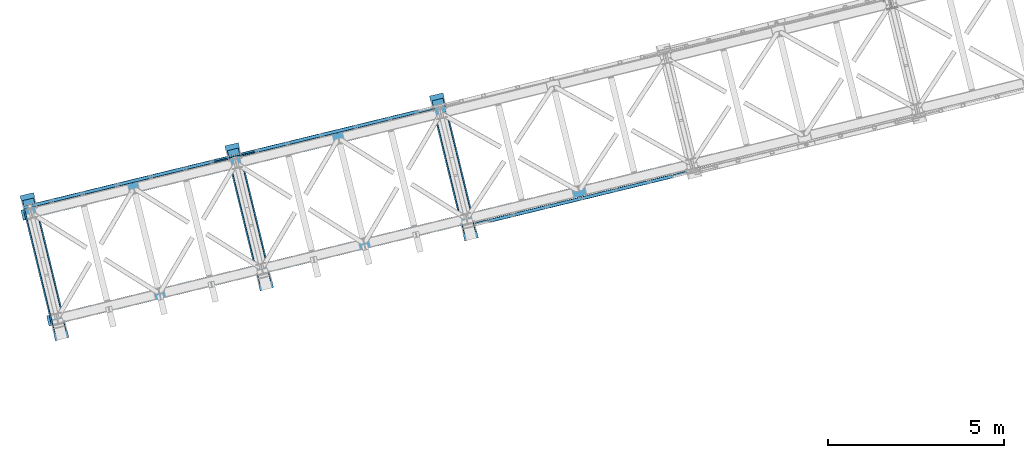
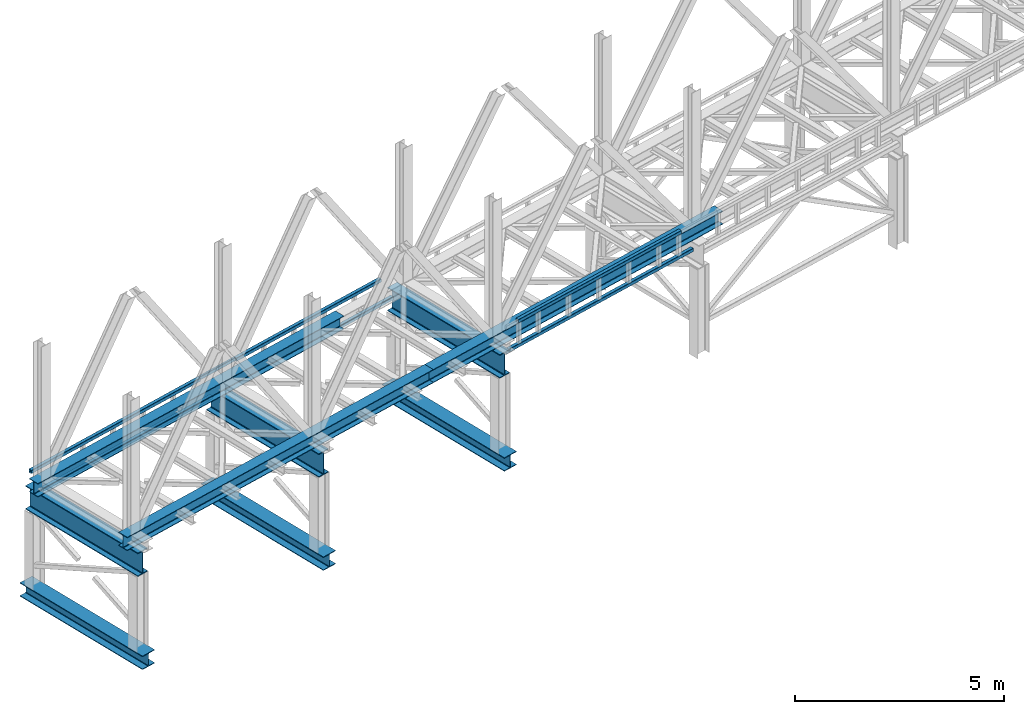
# One storey, part 15 of 92: 16 beams.
"""IFC4 building model written with IfcOpenShell, lengths in millimetres."""

from ifc_helpers import new_model, entity, si_unit, converted_unit, derived_unit, direction, frame, origin, place, context, subcontext, project, spatial, indexed_curve, outline, extrude, material, type_object, element, save


model = new_model("IFC4")

# Units and contexts
model_context = context("Model", 3, precision=0.01, world=origin(), true_north=direction((6.12303176911189e-17, 1.0)))
plan_context = context("Plan", 3, precision=0.01, world=origin(), true_north=direction((6.12303176911189e-17, 1.0)))
body_context = subcontext(model_context, "Body", "Model", "MODEL_VIEW")
ifc_project = project(units=[si_unit("LENGTHUNIT", "METRE", prefix="MILLI"), si_unit("AREAUNIT", "SQUARE_METRE"), si_unit("VOLUMEUNIT", "CUBIC_METRE"), converted_unit("PLANEANGLEUNIT", "DEGREE", entity("IfcRatioMeasure", 0.0174532925199433), si_unit("PLANEANGLEUNIT", "RADIAN"), dimensions=[0, 0, 0, 0, 0, 0, 0]), si_unit("MASSUNIT", "GRAM", prefix="KILO"), derived_unit("MASSDENSITYUNIT", [(si_unit("MASSUNIT", "GRAM", prefix="KILO"), 1), (si_unit("LENGTHUNIT", "METRE"), -3)]), derived_unit("MOMENTOFINERTIAUNIT", [(si_unit("LENGTHUNIT", "METRE"), 4)]), si_unit("TIMEUNIT", "SECOND"), si_unit("FREQUENCYUNIT", "HERTZ"), si_unit("THERMODYNAMICTEMPERATUREUNIT", "DEGREE_CELSIUS"), derived_unit("THERMALTRANSMITTANCEUNIT", [(si_unit("MASSUNIT", "GRAM", prefix="KILO"), 1), (si_unit("THERMODYNAMICTEMPERATUREUNIT", "KELVIN"), -1), (si_unit("TIMEUNIT", "SECOND"), -3)]), derived_unit("VOLUMETRICFLOWRATEUNIT", [(si_unit("LENGTHUNIT", "METRE"), 3), (si_unit("TIMEUNIT", "SECOND"), -1)]), derived_unit("MASSFLOWRATEUNIT", [(si_unit("MASSUNIT", "GRAM", prefix="KILO"), 1), (si_unit("TIMEUNIT", "SECOND"), -1)]), derived_unit("ROTATIONALFREQUENCYUNIT", [(si_unit("TIMEUNIT", "SECOND"), -1)]), si_unit("ELECTRICCURRENTUNIT", "AMPERE"), si_unit("ELECTRICVOLTAGEUNIT", "VOLT"), si_unit("POWERUNIT", "WATT"), si_unit("FORCEUNIT", "NEWTON", prefix="KILO"), si_unit("ILLUMINANCEUNIT", "LUX"), si_unit("LUMINOUSFLUXUNIT", "LUMEN"), si_unit("LUMINOUSINTENSITYUNIT", "CANDELA"), derived_unit("USERDEFINED", [(si_unit("MASSUNIT", "GRAM", prefix="KILO"), -1), (si_unit("LENGTHUNIT", "METRE"), -2), (si_unit("TIMEUNIT", "SECOND"), 3), (si_unit("LUMINOUSFLUXUNIT", "LUMEN"), 1)]), derived_unit("LINEARVELOCITYUNIT", [(si_unit("LENGTHUNIT", "METRE"), 1), (si_unit("TIMEUNIT", "SECOND"), -1)]), si_unit("PRESSUREUNIT", "PASCAL"), derived_unit("USERDEFINED", [(si_unit("LENGTHUNIT", "METRE"), -2), (si_unit("MASSUNIT", "GRAM", prefix="KILO"), 1), (si_unit("TIMEUNIT", "SECOND"), -2)]), derived_unit("LINEARFORCEUNIT", [(si_unit("MASSUNIT", "GRAM", prefix="KILO"), 1), (si_unit("LENGTHUNIT", "METRE"), 1), (si_unit("TIMEUNIT", "SECOND"), -2), (si_unit("LENGTHUNIT", "METRE"), -1)]), derived_unit("PLANARFORCEUNIT", [(si_unit("MASSUNIT", "GRAM", prefix="KILO"), 1), (si_unit("LENGTHUNIT", "METRE"), 1), (si_unit("TIMEUNIT", "SECOND"), -2), (si_unit("LENGTHUNIT", "METRE"), -2)])], contexts=[model_context, plan_context])

# Site, building, storey
site_placement = place(None, origin())
site = spatial("IfcSite", under=ifc_project, at=site_placement, CompositionType="ELEMENT")
building_placement = place(site_placement, origin())
building = spatial("IfcBuilding", under=site, at=building_placement, CompositionType="ELEMENT")
storey_placement = place(building_placement, frame((0.0, 0.0, 15900.0)))
storey = spatial("IfcBuildingStorey", under=building, at=storey_placement, Name="05", CompositionType="ELEMENT", Elevation=15900.0)

# Beams
ifc_material = material(Name="Metal painted (White)")
beam_type = type_object("IfcBeamType", PredefinedType="BEAM")
placement = place(storey_placement, origin())
element("IfcBeam", 1, at=placement, inside=storey, type_object=beam_type, material=ifc_material, ObjectType="Steel Beam", PredefinedType="BEAM", context=body_context, shape_type="SweptSolid", body=[
    extrude(outline(indexed_curve([(-199.999999999998, -200.000000000009), (-180.0, -200.000000000009), (-180.0, -28.500000000011), (-178.325349715245, -20.0809644879738), (-173.556349186101, -12.9436508139005), (-166.419035512029, -8.17465028475953), (-157.999999999999, -6.50000000000747), (158.000000000001, -6.50000000000747), (166.419035512033, -8.17465028475953), (173.556349186107, -12.9436508139005), (178.325349715251, -20.0809644879738), (180.000000000002, -28.500000000011), (180.000000000002, -200.000000000009), (200.0, -200.000000000009), (200.0, 199.999999999991), (180.000000000002, 199.999999999991), (180.000000000002, 28.4999999999932), (178.325349715247, 20.0809644879561), (173.556349186107, 12.9436508138827), (166.419035512033, 8.1746502847418), (158.000000000001, 6.49999999998974), (-157.999999999999, 6.49999999999861), (-166.419035512029, 8.17465028475066), (-173.556349186101, 12.9436508139005), (-178.325349715245, 20.080964487965), (-179.999999999998, 28.5000000000021), (-180.0, 199.999999999991), (-199.999999999998, 199.999999999991), (-199.999999999998, -200.000000000009)], self_intersect=False)), frame((-60133.55, 2325.82, 198.0), z_axis=(-0.236826092990339, 0.971552058141473, 0.0), x_axis=(0.0, 0.0, 1.0)), (0.0, 0.0, 1.0), 4250.00000000001),
])
element("IfcBeam", 2, at=placement, inside=storey, type_object=beam_type, material=ifc_material, ObjectType="Steel Beam", PredefinedType="BEAM", context=body_context, shape_type="SweptSolid", body=[
    extrude(outline(indexed_curve([(-345.500000000002, -160.000000000002), (-322.5, -160.000000000002), (-322.5, -37.4999999999994), (-320.216385975338, -26.0194970290429), (-313.713203435595, -16.2867965644056), (-303.980502970953, -9.78361402465815), (-292.499999999998, -7.49999999999633), (292.500000000001, -7.49999999999633), (303.980502970953, -9.78361402465815), (313.713203435597, -16.2867965644056), (320.21638597534, -26.0194970290429), (322.5, -37.4999999999994), (322.5, -160.000000000002), (345.499999999997, -160.000000000002), (345.499999999997, 160.000000000002), (322.5, 160.000000000002), (322.5, 37.4999999999994), (320.21638597534, 26.0194970290429), (313.713203435597, 16.2867965644056), (303.980502970953, 9.78361402465815), (292.500000000001, 7.49999999999633), (-292.499999999998, 7.50000000000526), (-303.980502970953, 9.78361402466708), (-313.713203435595, 16.2867965644056), (-320.216385975338, 26.0194970290429), (-322.5, 37.4999999999994), (-322.5, 160.000000000002), (-345.500000000002, 160.000000000002), (-345.500000000002, -160.000000000002)], self_intersect=False)), frame((-60180.91, 2520.13, 2947.5), z_axis=(-0.236826092990334, 0.971552058141474, 0.0), x_axis=(0.0, 0.0, 1.0)), (0.0, 0.0, 1.0), 3899.99999999999),
])
element("IfcBeam", 3, at=placement, inside=storey, type_object=beam_type, material=ifc_material, ObjectType="Steel Beam", PredefinedType="BEAM", context=body_context, shape_type="SweptSolid", body=[
    extrude(outline(indexed_curve([(-199.999999999998, -200.0), (-180.0, -200.0), (-180.0, -28.5000000000021), (-178.325349715245, -20.080964487965), (-173.556349186101, -12.9436508138917), (-166.419035512029, -8.17465028475066), (-157.999999999999, -6.49999999999867), (158.000000000001, -6.49999999999867), (166.419035512033, -8.17465028475066), (173.556349186107, -12.9436508138917), (178.325349715251, -20.080964487965), (180.000000000002, -28.5000000000021), (180.000000000002, -200.0), (200.0, -200.0), (200.0, 200.0), (180.000000000002, 200.0), (180.000000000002, 28.5000000000021), (178.325349715247, 20.080964487965), (173.556349186107, 12.9436508138917), (166.419035512033, 8.17465028475066), (158.000000000001, 6.49999999999854), (-157.999999999999, 6.50000000000747), (-166.419035512029, 8.17465028475959), (-173.556349186101, 12.9436508139094), (-178.325349715245, 20.0809644879738), (-179.999999999998, 28.500000000011), (-180.0, 200.0), (-199.999999999998, 200.0), (-199.999999999998, -200.0)], self_intersect=False)), frame((-54304.24, 3746.78, 198.0), z_axis=(-0.236826092990342, 0.971552058141472, 0.0), x_axis=(0.0, 0.0, 1.0)), (0.0, 0.0, 1.0), 4250.0),
])
element("IfcBeam", 4, at=placement, inside=storey, type_object=beam_type, material=ifc_material, ObjectType="Steel Beam", PredefinedType="BEAM", context=body_context, shape_type="SweptSolid", body=[
    extrude(outline(indexed_curve([(-345.500000000002, -159.999999999993), (-322.5, -159.999999999993), (-322.5, -37.4999999999906), (-320.216385975338, -26.0194970290341), (-313.713203435595, -16.2867965643968), (-303.980502970953, -9.78361402464935), (-292.499999999998, -7.4999999999874), (292.500000000001, -7.4999999999874), (303.980502970953, -9.78361402464935), (313.713203435597, -16.2867965643968), (320.21638597534, -26.0194970290341), (322.5, -37.4999999999906), (322.5, -159.999999999993), (345.499999999997, -159.999999999993), (345.499999999997, 160.000000000011), (322.5, 160.000000000011), (322.5, 37.5000000000083), (320.21638597534, 26.0194970290519), (313.713203435597, 16.2867965644145), (303.980502970953, 9.78361402466708), (292.500000000001, 7.50000000000526), (-292.499999999998, 7.50000000001406), (-303.980502970953, 9.78361402466708), (-313.713203435595, 16.2867965644145), (-320.216385975338, 26.0194970290519), (-322.5, 37.5000000000083), (-322.5, 160.000000000011), (-345.500000000002, 160.000000000011), (-345.500000000002, -159.999999999993)], self_intersect=False)), frame((-54351.6, 3941.09, 2947.5), z_axis=(-0.236826092990334, 0.971552058141474, 0.0), x_axis=(0.0, 0.0, 1.0)), (0.0, 0.0, 1.0), 3899.99999999999),
])
element("IfcBeam", 5, at=placement, inside=storey, type_object=beam_type, material=ifc_material, ObjectType="Steel Beam", PredefinedType="BEAM", context=body_context, shape_type="SweptSolid", body=[
    extrude(outline(indexed_curve([(-199.999999999998, -199.999999999992), (-180.0, -199.999999999992), (-180.0, -28.4999999999933), (-178.325349715245, -20.0809644879649), (-173.556349186101, -12.9436508138917), (-166.419035512029, -8.17465028474173), (-157.999999999999, -6.49999999999867), (158.000000000001, -6.49999999999867), (166.419035512033, -8.17465028474173), (173.556349186107, -12.9436508138917), (178.325349715251, -20.0809644879649), (180.000000000002, -28.4999999999933), (180.000000000002, -199.999999999992), (200.0, -199.999999999992), (200.0, 200.000000000009), (180.000000000002, 200.000000000009), (180.000000000002, 28.5000000000022), (178.325349715247, 20.0809644879738), (173.556349186107, 12.9436508139006), (166.419035512033, 8.17465028475959), (158.000000000001, 6.5000000000076), (-157.999999999999, 6.50000000001628), (-166.419035512029, 8.17465028476852), (-173.556349186101, 12.9436508139095), (-178.325349715245, 20.0809644879828), (-179.999999999998, 28.5000000000198), (-180.0, 200.000000000009), (-199.999999999998, 200.000000000009), (-199.999999999998, -199.999999999992)], self_intersect=False)), frame((-48474.92, 5167.73, 198.0), z_axis=(-0.236826092990345, 0.971552058141471, 0.0), x_axis=(0.0, 0.0, 1.0)), (0.0, 0.0, 1.0), 4250.00000000001),
])
element("IfcBeam", 6, at=placement, inside=storey, type_object=beam_type, material=ifc_material, ObjectType="Steel Beam", PredefinedType="BEAM", context=body_context, shape_type="SweptSolid", body=[
    extrude(outline(indexed_curve([(-345.500000000002, -160.00000000001), (-322.5, -160.00000000001), (-322.5, -37.5000000000082), (-320.216385975338, -26.0194970290607), (-313.713203435595, -16.2867965644145), (-303.980502970953, -9.78361402467601), (-292.499999999998, -7.50000000000526), (292.500000000001, -7.50000000000526), (303.980502970953, -9.78361402467601), (313.713203435597, -16.2867965644145), (320.21638597534, -26.0194970290607), (322.5, -37.5000000000082), (322.5, -160.00000000001), (345.499999999997, -160.00000000001), (345.499999999997, 159.999999999993), (322.5, 159.999999999993), (322.5, 37.4999999999906), (320.21638597534, 26.0194970290341), (313.713203435597, 16.2867965643967), (303.980502970953, 9.78361402464922), (292.500000000001, 7.4999999999874), (-292.499999999998, 7.49999999999633), (-303.980502970953, 9.78361402465815), (-313.713203435595, 16.2867965643967), (-320.216385975338, 26.0194970290431), (-322.5, 37.4999999999906), (-322.5, 159.999999999993), (-345.500000000002, 159.999999999993), (-345.500000000002, -160.00000000001)], self_intersect=False)), frame((-48522.29, 5362.04, 2947.5), z_axis=(-0.23682609299033, 0.971552058141475, 0.0), x_axis=(0.0, 0.0, 1.0)), (0.0, 0.0, 1.0), 3899.99999999999),
])
element("IfcBeam", 7, at=placement, inside=storey, type_object=beam_type, material=ifc_material, ObjectType="Steel Beam", PredefinedType="BEAM", context=body_context, shape_type="SweptSolid", body=[
    extrude(outline(indexed_curve([(-195.999999999999, -150.000000000005), (-179.999999999996, -150.000000000005), (-179.999999999996, -27.7500000000052), (-178.325349715245, -19.3309644879708), (-173.556349186101, -12.1936508139001), (-166.419035512029, -7.42465028475701), (-157.999999999997, -5.75000000000373), (158.000000000005, -5.75000000000373), (166.419035512033, -7.42465028475701), (173.556349186107, -12.1936508139001), (178.325349715251, -19.3309644879708), (180.0, -27.7500000000052), (180.0, -150.000000000005), (196.000000000005, -150.000000000005), (196.000000000005, 149.999999999996), (180.0, 149.999999999996), (180.0, 27.7499999999967), (178.325349715251, 19.3309644879629), (173.556349186107, 12.1936508138912), (166.419035512033, 7.42465028474807), (158.000000000005, 5.74999999999531), (-157.999999999997, 5.74999999999689), (-166.419035512029, 7.42465028474965), (-173.556349186101, 12.1936508138933), (-178.325349715245, 19.3309644879639), (-179.999999999996, 27.7499999999973), (-179.999999999996, 149.999999999999), (-195.999999999999, 149.999999999996), (-195.999999999999, -150.000000000005)], self_intersect=False)), frame((-60542.82, 2843.62, 3489.0), z_axis=(0.971552058141477, 0.236826092990323, 0.0), x_axis=(0.0, 0.0, 1.0)), (0.0, 0.0, 1.0), 10150.0),
])
element("IfcBeam", 8, at=placement, inside=storey, type_object=beam_type, material=ifc_material, ObjectType="Steel Beam", PredefinedType="BEAM", context=body_context, shape_type="SweptSolid", body=[
    extrude(outline(indexed_curve([(-195.999999999999, -150.000000000001), (-179.999999999996, -150.000000000001), (-179.999999999996, -27.750000000002), (-178.325349715245, -19.330964487966), (-173.556349186101, -12.1936508138954), (-166.419035512029, -7.4246502847528), (-157.999999999997, -5.75000000000005), (158.000000000005, -5.75000000000005), (166.419035512033, -7.4246502847528), (173.556349186107, -12.1936508138954), (178.325349715251, -19.330964487966), (180.0, -27.750000000002), (180.0, -150.000000000001), (196.000000000005, -150.000000000001), (196.000000000005, 150.000000000001), (180.0, 150.000000000001), (180.0, 27.750000000002), (178.325349715251, 19.330964487966), (173.556349186107, 12.1936508138954), (166.419035512033, 7.42465028475175), (158.000000000005, 5.75000000000005), (-157.999999999997, 5.75000000000005), (-166.419035512029, 7.4246502847528), (-173.556349186101, 12.1936508138965), (-178.325349715245, 19.3309644879681), (-179.999999999996, 27.750000000002), (-179.999999999996, 150.000000000001), (-195.999999999999, 150.000000000001), (-195.999999999999, -150.000000000001)], self_intersect=False)), frame((-50681.57, 5247.41, 3489.0), z_axis=(0.971552058141476, 0.236826092990324, 0.0), x_axis=(0.0, 0.0, 1.0)), (0.0, 0.0, 1.0), 9600.0),
])
element("IfcBeam", 9, at=placement, inside=storey, type_object=beam_type, material=ifc_material, ObjectType="Steel Beam", PredefinedType="BEAM", context=body_context, shape_type="SweptSolid", body=[
    extrude(outline(indexed_curve([(-195.999999999999, -150.0), (-179.999999999996, -150.0), (-179.999999999996, -27.7499999999988), (-178.325349715245, -19.330964487965), (-173.556349186101, -12.1936508138944), (-166.419035512029, -7.4246502847507), (-157.999999999997, -5.74999999999794), (158.000000000005, -5.74999999999794), (166.419035512033, -7.4246502847507), (173.556349186107, -12.1936508138944), (178.325349715251, -19.330964487965), (180.0, -27.7499999999988), (180.0, -150.0), (196.000000000005, -150.0), (196.000000000005, 150.000000000003), (180.0, 150.000000000003), (180.0, 27.7500000000031), (178.325349715251, 19.3309644879681), (173.556349186107, 12.1936508138986), (166.419035512033, 7.42465028475491), (158.000000000005, 5.75000000000215), (-157.999999999997, 5.7500000000032), (-166.419035512029, 7.42465028475491), (-173.556349186101, 12.1936508138996), (-178.325349715247, 19.3309644879681), (-179.999999999996, 27.7500000000031), (-179.999999999996, 150.000000000003), (-195.999999999999, 150.000000000003), (-195.999999999999, -150.0)], self_intersect=False)), frame((-61276.98, 5855.44, 3489.0), z_axis=(0.971552058141477, 0.23682609299032, 0.0), x_axis=(0.0, 0.0, 1.0)), (0.0, 0.0, 1.0), 10150.0),
])
element("IfcBeam", 10, at=placement, inside=storey, type_object=beam_type, material=ifc_material, ObjectType="Steel Beam", PredefinedType="BEAM", context=body_context, shape_type="SweptSolid", body=[
    extrude(outline(indexed_curve([(29.4768951153388, -56.8428769007951), (33.3787015556623, -56.8428769007951), (36.9835006656957, -55.3497202197886), (39.7424944585247, -52.5907264269583), (41.2356511395302, -48.9859273169241), (56.8428769008066, 29.4768951153362), (56.8428769008059, 33.3787015556666), (55.3497202197987, 36.9835006656969), (52.5907264269695, 39.7424944585246), (48.9859273169341, 41.2356511395347), (-29.4768951153272, 56.8428769008105), (-33.3787015556515, 56.8428769008063), (-36.9835006656859, 55.3497202197999), (-39.7424944585131, 52.5907264269737), (-41.2356511395192, 48.9859273169308), (-56.8428769007946, -29.4768951153297), (-56.8428769007963, -33.3787015556508), (-55.349720219789, -36.9835006656856), (-52.5907264269576, -39.7424944585136), (-48.9859273169225, -41.2356511395193), (29.4768951153388, -56.8428769007951)], self_intersect=False), holes=[indexed_curve([(-50.9634988887029, -25.5484203233846), (-37.3071763475863, 43.1065493048366), (-35.8140196665766, 46.7113484148699), (-33.0550258737478, 49.4703422077047), (-29.4502267637124, 50.9634988887108), (-25.548420323392, 50.9634988887114), (43.1065493048361, 37.3071763475952), (46.7113484148701, 35.8140196665898), (49.4703422076984, 33.0550258737623), (50.963498888707, 29.4502267637229), (50.9634988887104, 25.5484203234008), (37.3071763475958, -43.1065493048208), (35.8140196665845, -46.7113484148627), (33.0550258737576, -49.4703422076934), (29.4502267637232, -50.9634988886997), (25.5484203234048, -50.9634988887007), (-43.1065493048284, -37.3071763475835), (-46.7113484148604, -35.8140196665785), (-49.4703422076917, -33.0550258737504), (-50.9634988887022, -29.450226763715), (-50.9634988887029, -25.5484203233846)], self_intersect=False)]), frame((-61247.59, 6068.46, 3830.0), z_axis=(0.971552058141251, 0.23682609299125, 0.0), x_axis=(0.232275546020893, -0.95288395777052, -0.195090322015947)), (0.0, 0.0, 1.0), 5595.99999999999),
])
element("IfcBeam", 11, at=placement, inside=storey, type_object=beam_type, material=ifc_material, ObjectType="Steel Beam", PredefinedType="BEAM", context=body_context, shape_type="SweptSolid", body=[
    extrude(outline(indexed_curve([(29.4768951153018, -56.8428769008144), (33.3787015556258, -56.8428769008144), (36.9835006656596, -55.3497202198119), (39.7424944584905, -52.590726426981), (41.2356511394979, -48.9859273169476), (56.842876900814, 29.4768951153048), (56.8428769008189, 33.3787015556257), (55.3497202198128, 36.9835006656636), (52.590726426984, 39.7424944584929), (48.9859273169497, 41.2356511395006), (-29.4768951153031, 56.8428769008191), (-33.3787015556266, 56.8428769008212), (-36.9835006656618, 55.3497202198168), (-39.7424944584927, 52.5907264269859), (-41.2356511395002, 48.9859273169525), (-56.8428769008193, -29.4768951152993), (-56.8428769008191, -33.3787015556212), (-55.3497202198151, -36.9835006656587), (-52.5907264269859, -39.742494458486), (-48.985927316952, -41.2356511394957), (29.4768951153018, -56.8428769008144)], self_intersect=False), holes=[indexed_curve([(-50.963498888721, -25.5484203233671), (-37.3071763475673, 43.1065493048556), (-35.8140196665578, 46.7113484148885), (-33.0550258737259, 49.4703422077192), (-29.4502267636906, 50.9634988887236), (-25.5484203233702, 50.9634988887221), (43.1065493048524, 37.3071763475682), (46.7113484148847, 35.8140196665609), (49.4703422077155, 33.0550258737312), (50.9634988887216, 29.4502267636933), (50.9634988887187, 25.548420323372), (37.3071763475661, -43.1065493048509), (35.8140196665545, -46.7113484148834), (33.055025873724, -49.4703422077122), (29.4502267636888, -50.9634988887166), (25.5484203233694, -50.9634988887153), (-43.1065493048538, -37.3071763475591), (-46.711348414883, -35.8140196665524), (-49.4703422077128, -33.0550258737229), (-50.9634988887218, -29.4502267636888), (-50.963498888721, -25.5484203233671)], self_intersect=False)]), frame((-60866.75, 6161.29, 3118.0), z_axis=(0.971552058141251, 0.23682609299125, 0.0), x_axis=(-0.232275546020868, 0.952883957770417, 0.195090322016481)), (0.0, 0.0, 1.0), 5603.99999999999),
])
element("IfcBeam", 12, at=placement, inside=storey, type_object=beam_type, material=ifc_material, ObjectType="Steel Beam", PredefinedType="BEAM", context=body_context, shape_type="SweptSolid", body=[
    extrude(outline(indexed_curve([(29.4768951153008, -56.8428769008142), (33.3787015556247, -56.8428769008142), (36.9835006656585, -55.3497202198117), (39.7424944584895, -52.5907264269808), (41.2356511394969, -48.9859273169474), (56.842876900813, 29.476895115305), (56.8428769008179, 33.3787015556259), (55.3497202198118, 36.9835006656638), (52.590726426983, 39.7424944584932), (48.9859273169487, 41.2356511395008), (-29.4768951153041, 56.8428769008193), (-33.3787015556276, 56.8428769008214), (-36.9835006656628, 55.349720219817), (-39.7424944584938, 52.5907264269861), (-41.2356511395012, 48.9859273169527), (-56.8428769008204, -29.4768951152991), (-56.8428769008201, -33.378701555621), (-55.3497202198161, -36.9835006656585), (-52.5907264269869, -39.7424944584858), (-48.985927316952, -41.2356511394957), (29.4768951153008, -56.8428769008142)], self_intersect=False), holes=[indexed_curve([(-50.9634988887189, -25.5484203233675), (-37.3071763475663, 43.1065493048554), (-35.8140196665568, 46.7113484148883), (-33.0550258737259, 49.4703422077192), (-29.4502267636906, 50.9634988887236), (-25.5484203233702, 50.9634988887221), (43.1065493048514, 37.3071763475684), (46.7113484148847, 35.8140196665609), (49.4703422077155, 33.0550258737312), (50.9634988887226, 29.450226763693), (50.9634988887208, 25.5484203233716), (37.3071763475671, -43.1065493048511), (35.8140196665545, -46.7113484148834), (33.0550258737261, -49.4703422077126), (29.4502267636888, -50.9634988887166), (25.5484203233684, -50.9634988887151), (-43.1065493048518, -37.3071763475595), (-46.711348414883, -35.8140196665524), (-49.4703422077128, -33.0550258737229), (-50.9634988887197, -29.4502267636892), (-50.9634988887189, -25.5484203233675)], self_intersect=False)]), frame((-55033.55, 7583.19, 3118.0), z_axis=(0.971552058141251, 0.23682609299125, 0.0), x_axis=(-0.232275546020868, 0.952883957770417, 0.195090322016481)), (0.0, 0.0, 1.0), 5600.00000000001),
])
element("IfcBeam", 13, at=placement, inside=storey, type_object=beam_type, material=ifc_material, ObjectType="Steel Beam", PredefinedType="BEAM", context=body_context, shape_type="SweptSolid", body=[
    extrude(outline(indexed_curve([(29.4768951153378, -56.8428769007949), (33.3787015556613, -56.8428769007949), (36.9835006656947, -55.3497202197884), (39.7424944585237, -52.5907264269581), (41.2356511395291, -48.9859273169239), (56.8428769008073, 29.4768951153449), (56.8428769008049, 33.3787015556668), (55.3497202197977, 36.9835006656971), (52.5907264269684, 39.7424944585248), (48.9859273169331, 41.2356511395349), (-29.4768951153282, 56.8428769008107), (-33.3787015556525, 56.8428769008065), (-36.983500665687, 55.3497202198001), (-39.7424944585141, 52.5907264269739), (-41.2356511395206, 48.9859273169399), (-56.8428769007957, -29.4768951153295), (-56.8428769007974, -33.3787015556506), (-55.34972021979, -36.9835006656854), (-52.5907264269587, -39.7424944585134), (-48.9859273169235, -41.2356511395191), (29.4768951153378, -56.8428769007949)], self_intersect=False), holes=[indexed_curve([(-50.9634988887029, -25.5484203233846), (-37.3071763475873, 43.1065493048368), (-35.8140196665787, 46.7113484148704), (-33.0550258737499, 49.4703422077051), (-29.4502267637124, 50.9634988887108), (-25.548420323393, 50.9634988887117), (43.1065493048361, 37.3071763475952), (46.711348414866, 35.8140196665906), (49.4703422076974, 33.0550258737625), (50.963498888707, 29.4502267637229), (50.9634988887094, 25.548420323401), (37.3071763475958, -43.1065493048208), (35.8140196665835, -46.7113484148625), (33.0550258737566, -49.4703422076932), (29.4502267637221, -50.9634988886995), (25.5484203234017, -50.9634988887001), (-43.1065493048284, -37.3071763475835), (-46.7113484148614, -35.8140196665783), (-49.4703422076938, -33.05502587375), (-50.9634988887022, -29.450226763715), (-50.9634988887029, -25.5484203233846)], self_intersect=False)]), frame((-54644.93, 7677.93, 3830.0), z_axis=(0.971552058141251, 0.23682609299125, 0.0), x_axis=(0.232275546020893, -0.95288395777052, -0.195090322015947)), (0.0, 0.0, 1.0), 4799.99999999999),
])
element("IfcBeam", 14, at=placement, inside=storey, type_object=beam_type, material=ifc_material, ObjectType="Steel Beam", PredefinedType="BEAM", context=body_context, shape_type="SweptSolid", body=[
    extrude(outline(indexed_curve([(9.86118950714915, -52.9410704605091), (13.7629959474743, -52.9410704605091), (17.3677950575112, -51.4479137795148), (20.126788850346, -48.6889199866861), (21.6199455313573, -45.0841208766548), (37.2271712928046, 33.3787015555715), (37.2271712928149, 37.2805079958926), (35.7340146118143, 40.8853071059309), (32.97502081899, 43.6443008987647), (29.370221708959, 45.1374575797825), (-9.86118950715515, 52.9410704605059), (-13.7629959474785, 52.9410704605099), (-17.3677950575151, 51.4479137795112), (-20.1267888503512, 48.6889199866871), (-21.6199455313625, 45.0841208766558), (-37.2271712928098, -33.3787015555705), (-37.227171292819, -37.2805079958918), (-35.7340146118193, -40.8853071059343), (-32.9750208189972, -43.6443008987633), (-29.370221708965, -45.1374575797857), (9.86118950714915, -52.9410704605091)], self_intersect=False), holes=[indexed_curve([(-31.347793280705, -29.4502267636479), (-17.6914707394412, 39.2047428645529), (-16.1983140584258, 42.8095419745834), (-13.4393202655939, 45.5685357674083), (-9.83452115555316, 47.0616924484062), (-5.9327147152307, 47.0616924483979), (23.4908436968534, 41.2089827878556), (27.0956428068832, 39.7158261068425), (29.8546365997095, 36.9568323140083), (31.3477932807091, 33.3520332039702), (31.347793280702, 29.4502267636485), (17.6914707394371, -39.204742864552), (16.1983140584197, -42.8095419745821), (13.4393202655828, -45.5685357674105), (9.83452115554697, -47.0616924484049), (5.9327147152276, -47.0616924483973), (-23.4908436968606, -41.2089827878542), (-27.0956428068904, -39.7158261068411), (-29.8546365997137, -36.9568323140075), (-31.3477932807122, -33.3520332039696), (-31.347793280705, -29.4502267636479)], self_intersect=False)]), frame((-55815.53, 7413.16, 3830.0), z_axis=(0.971552058141243, 0.236826092991282, 0.0), x_axis=(-0.232275546020792, 0.952883957770107, 0.195090322018083)), (0.0, 0.0, 1.0), 1200.0),
])
element("IfcBeam", 15, at=placement, inside=storey, type_object=beam_type, material=ifc_material, ObjectType="Steel Beam", PredefinedType="BEAM", context=body_context, shape_type="SweptSolid", body=[
    extrude(outline(indexed_curve([(29.4768951153272, -56.8428769008016), (33.3787015556497, -56.8428769008016), (36.9835006656846, -55.3497202197933), (39.7424944585133, -52.5907264269652), (41.23565113952, -48.9859273169314), (56.8428769007987, 29.4768951153285), (56.842876900798, 33.3787015556523), (55.3497202197922, 36.9835006656891), (52.5907264269616, 39.742494458515), (48.9859273169276, 41.2356511395206), (-29.4768951153358, 56.8428769008011), (-33.3787015556583, 56.8428769008011), (-36.9835006656924, 55.349720219797), (-39.7424944585189, 52.5907264269641), (-41.235651139526, 48.9859273169281), (-56.8428769008057, -29.4768951153315), (-56.8428769008046, -33.3787015556532), (-55.349720219798, -36.9835006656858), (-52.5907264269683, -39.7424944585159), (-48.9859273169342, -41.2356511395215), (29.4768951153272, -56.8428769008016)], self_intersect=False), holes=[indexed_curve([(-50.9634988887062, -25.548420323397), (-37.3071763475882, 43.1065493048327), (-35.8140196665846, 46.7113484148672), (-33.055025873755, 49.4703422076995), (-29.4502267637201, 50.9634988887078), (-25.5484203233946, 50.9634988887072), (43.1065493048316, 37.3071763475877), (46.7113484148708, 35.814019666581), (49.4703422076995, 33.0550258737511), (50.9634988887042, 29.4502267637145), (50.9634988887054, 25.5484203233928), (37.3071763475853, -43.1065493048366), (35.8140196665786, -46.7113484148704), (33.0550258737485, -49.4703422077004), (29.4502267637144, -50.9634988887044), (25.5484203233919, -50.9634988887045), (-43.1065493048343, -37.3071763475849), (-46.7113484148714, -35.8140196665787), (-49.4703422077005, -33.0550258737509), (-50.9634988887051, -29.4502267637187), (-50.9634988887062, -25.548420323397)], self_intersect=False)]), frame((-48373.21, 5594.98, 3118.0), z_axis=(0.97155205814122, 0.236826092991375, 0.0), x_axis=(-0.232275546020954, 0.952883957770495, 0.195090322015999)), (0.0, 0.0, 1.0), 6199.99999999998),
])
element("IfcBeam", 16, at=placement, inside=storey, type_object=beam_type, material=ifc_material, ObjectType="Steel Beam", PredefinedType="BEAM", context=body_context, shape_type="SweptSolid", body=[
    extrude(outline(indexed_curve([(29.4768951153305, -56.8428769007956), (33.378701555653, -56.8428769007956), (36.9835006656875, -55.3497202197894), (39.7424944585167, -52.5907264269593), (41.2356511395223, -48.9859273169252), (56.842876900802, 29.4768951153345), (56.8428769008026, 33.3787015556647), (55.3497202197956, 36.9835006656951), (52.5907264269654, 39.7424944585231), (48.9859273169322, 41.235651139533), (-29.4768951153282, 56.8428769008128), (-33.3787015556525, 56.8428769008088), (-36.9835006656871, 55.3497202198026), (-39.7424944585143, 52.5907264269765), (-41.2356511395227, 48.9859273169341), (-56.8428769008024, -29.4768951153256), (-56.8428769008013, -33.3787015556473), (-55.3497202197951, -36.9835006656819), (-52.5907264269649, -39.7424944585099), (-48.9859273169299, -41.2356511395158), (29.4768951153305, -56.8428769007956)], self_intersect=False), holes=[indexed_curve([(-50.9634988887043, -25.548420323382), (-37.3071763475849, 43.1065493048387), (-35.8140196665772, 46.7113484148724), (-33.0550258737493, 49.4703422077072), (-29.4502267637147, 50.9634988887134), (-25.5484203233923, 50.9634988887134), (43.1065493048329, 37.307176347594), (46.711348414871, 35.8140196665876), (49.4703422076991, 33.05502587376), (50.9634988887065, 29.4502267637207), (50.9634988887077, 25.548420323399), (37.3071763475893, -43.1065493048219), (35.814019666582, -46.7113484148645), (33.0550258737518, -49.4703422076944), (29.4502267637173, -50.9634988887006), (25.5484203233938, -50.9634988887004), (-43.1065493048324, -37.3071763475809), (-46.7113484148695, -35.8140196665746), (-49.4703422076986, -33.0550258737468), (-50.9634988887059, -29.450226763712), (-50.9634988887043, -25.548420323382)], self_intersect=False)]), frame((-47984.59, 5689.71, 3830.0), z_axis=(0.97155205814122, 0.236826092991375, 0.0), x_axis=(0.232275546020954, -0.952883957770495, -0.195090322015999)), (0.0, 0.0, 1.0), 5400.00000000001),
])

save(model, "model.ifc")
